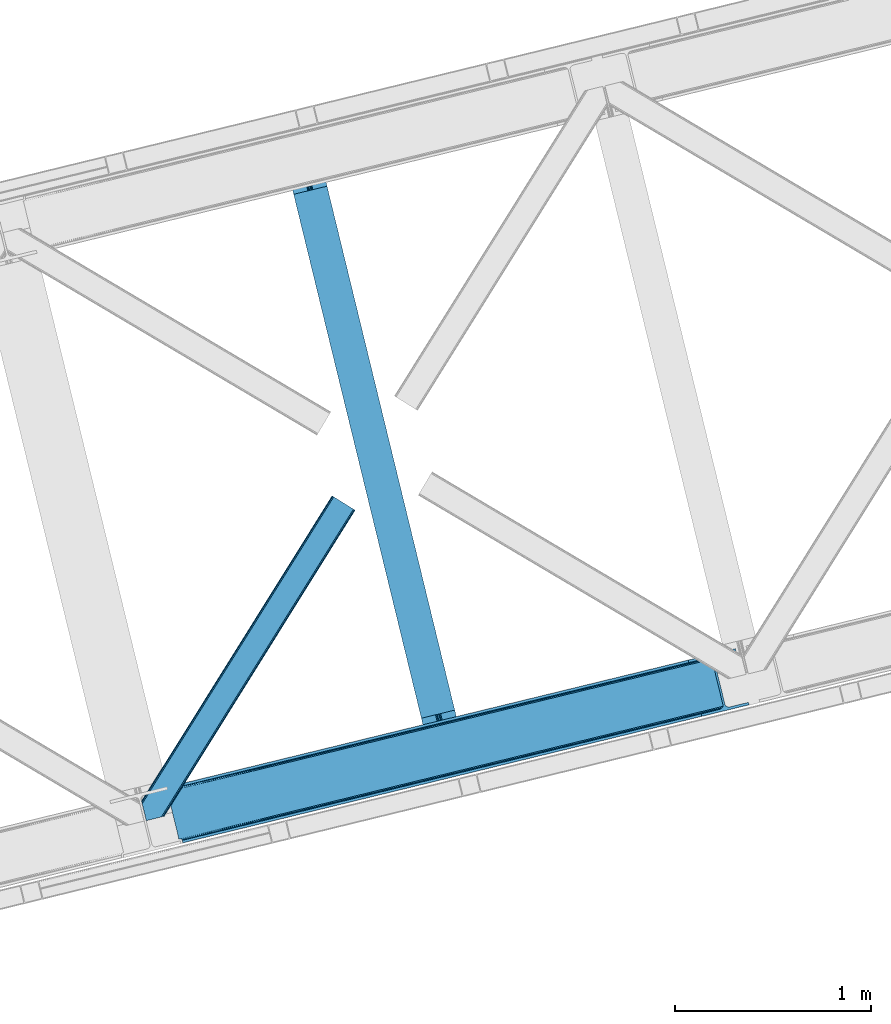
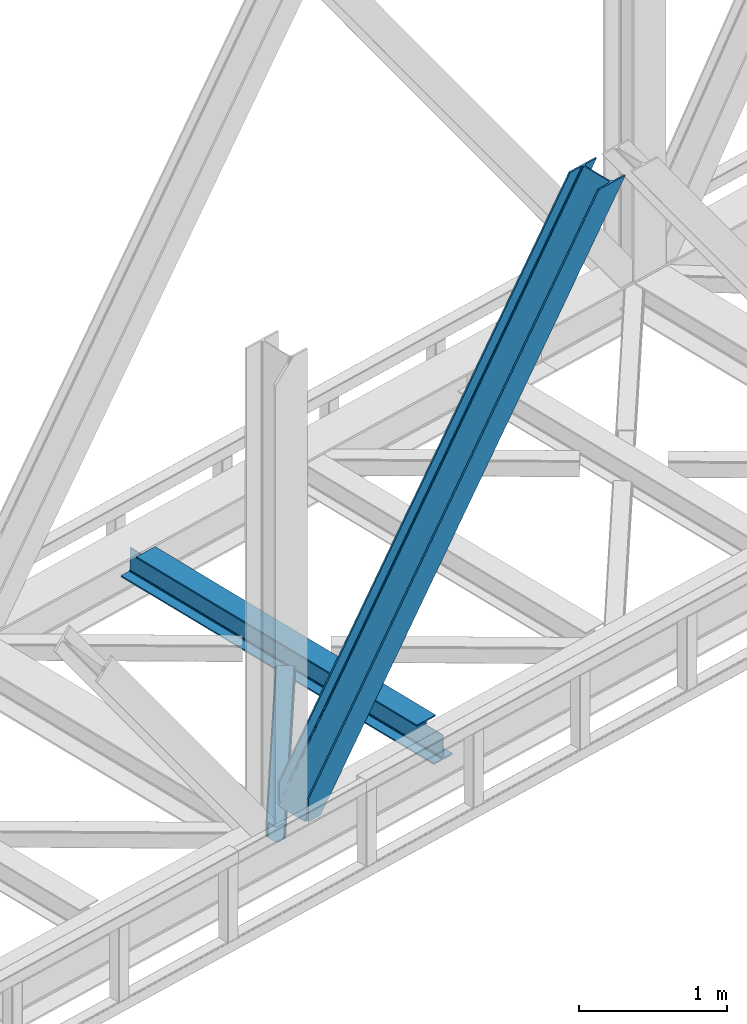
# One storey, part 67 of 93: 2 members, 1 beam.
"""IFC4 building model written with IfcOpenShell, lengths in millimetres."""

import ifcopenshell
import ifcopenshell.guid

model = None  # the IFC model being written
_history = None  # IfcOwnerHistory: only IFC2X3 demands one
_inside = {}  # id of a spatial element -> (the spatial element, [elements in it])
_under = {}  # id of a project, library or spatial element -> (it, [spatial elements below it])
_declared = {}  # id of a project -> (the project, [libraries it declares])
_typed = {}  # id of a type object -> (the type object, [elements of that type])
_made_of = {}  # id of a material, layer set ... -> (it, [elements and type objects made of it])


def new_model(schema):
    """Start an empty IFC model of exactly this schema.

    Asked for "IFC4X3", IfcOpenShell would pick the latest addendum, in which some entities
    have other attributes; the version numbers below select the first issue.
    IFC2X3 requires an IfcOwnerHistory on every rooted entity: one is made here for all.
    """
    global model, _history
    if schema == "IFC4X3":
        model = ifcopenshell.file(schema_version=(4, 3, 0, 0))
    else:
        model = ifcopenshell.file(schema=schema)
    _inside.clear()
    _under.clear()
    _declared.clear()
    _typed.clear()
    _made_of.clear()
    _history = None
    if model.schema == "IFC2X3":
        org = make("IfcOrganization", Name="unknown")
        user = make(
            "IfcPersonAndOrganization",
            ThePerson=make("IfcPerson", FamilyName="unknown"),
            TheOrganization=org,
        )
        app = make(
            "IfcApplication",
            ApplicationDeveloper=org,
            Version="unknown",
            ApplicationFullName="unknown",
            ApplicationIdentifier="unknown",
        )
        _history = make(
            "IfcOwnerHistory",
            OwningUser=user,
            OwningApplication=app,
            ChangeAction="ADDED",
            CreationDate=0,
        )
    return model


def make(cls, **values):
    """One entity of the class cls with the attributes given. An attribute that is None is left unset."""
    return model.create_entity(
        cls, **{name: value for name, value in values.items() if value is not None}
    )


def entity(cls, *values):
    """Any entity or typed value of the class cls, its attributes in the order of the schema. None: left unset."""
    e = model.create_entity(cls)
    for i, value in enumerate(values):
        if value is not None:
            e[i] = value
    return e


def rooted(cls, **values):
    """An entity with a GlobalId (a new one), such as an element, a storey or a relation."""
    return make(cls, GlobalId=ifcopenshell.guid.new(), OwnerHistory=_history, **values)


def si_unit(unit_type, name, prefix=None):
    """IfcSIUnit, for example si_unit("LENGTHUNIT", "METRE", prefix="MILLI")."""
    return make("IfcSIUnit", UnitType=unit_type, Prefix=prefix, Name=name)


def converted_unit(unit_type, name, factor, base, dimensions=None, offset=None):
    """IfcConversionBasedUnit, such as the inch: factor (a typed value) times the base unit."""
    return make(
        "IfcConversionBasedUnit"
        if offset is None
        else "IfcConversionBasedUnitWithOffset",
        ConversionOffset=offset,
        Dimensions=None
        if dimensions is None
        else entity("IfcDimensionalExponents", *dimensions),
        UnitType=unit_type,
        Name=name,
        ConversionFactor=make(
            "IfcMeasureWithUnit", ValueComponent=factor, UnitComponent=base
        ),
    )


def derived_unit(unit_type, elements):
    """IfcDerivedUnit: a product of units, each with its exponent."""
    return make(
        "IfcDerivedUnit",
        Elements=[
            make("IfcDerivedUnitElement", Unit=unit, Exponent=power)
            for unit, power in elements
        ],
        UnitType=unit_type,
    )


def assignment(units):
    """IfcUnitAssignment: the units of a project."""
    return None if units is None else make("IfcUnitAssignment", Units=units)


def point(xyz):
    """IfcCartesianPoint."""
    return None if xyz is None else make("IfcCartesianPoint", Coordinates=xyz)


def direction(xyz):
    """IfcDirection."""
    return None if xyz is None else make("IfcDirection", DirectionRatios=xyz)


def frame(location, z_axis=None, x_axis=None):
    """IfcAxis2Placement3D, a coordinate frame: its origin and axes. An axis left out is left unset."""
    return make(
        "IfcAxis2Placement3D",
        Location=point(location),
        Axis=direction(z_axis),
        RefDirection=direction(x_axis),
    )


def origin():
    """The frame at (0, 0, 0) with its axes left unset."""
    return frame((0.0, 0.0, 0.0))


def place(relative_to, where):
    """IfcLocalPlacement: puts the frame where relative to a parent placement (None: the world)."""
    return make(
        "IfcLocalPlacement", PlacementRelTo=relative_to, RelativePlacement=where
    )


def context(
    kind, dimensions, precision=None, world=None, true_north=None, identifier=None
):
    """IfcGeometricRepresentationContext, for example the 3D "Model" context."""
    return make(
        "IfcGeometricRepresentationContext",
        ContextIdentifier=identifier,
        ContextType=kind,
        CoordinateSpaceDimension=dimensions,
        Precision=precision,
        WorldCoordinateSystem=world,
        TrueNorth=true_north,
    )


def subcontext(parent, identifier, kind, view, scale=None):
    """IfcGeometricRepresentationSubContext, for example "Body" below "Model"."""
    return make(
        "IfcGeometricRepresentationSubContext",
        ContextIdentifier=identifier,
        ContextType=kind,
        ParentContext=parent,
        TargetScale=scale,
        TargetView=view,
    )


def project(units=None, contexts=None):
    """IfcProject with its units and contexts."""
    return rooted(
        "IfcProject",
        Name="project",
        RepresentationContexts=contexts,
        UnitsInContext=assignment(units),
    )


def spatial(cls, under=None, at=None, **own):
    """A site, building, storey or space (cls), placed at a placement, below another one or the project."""
    s = rooted(cls, ObjectPlacement=at, **own)
    if under is not None:
        _under.setdefault(under.id(), (under, []))[1].append(s)
    return s


def point_list(points):
    """IfcCartesianPointList2D or 3D."""
    cls = (
        "IfcCartesianPointList2D" if len(points[0]) == 2 else "IfcCartesianPointList3D"
    )
    return make(cls, CoordList=points)


def triangles(points, corners, closed=None, point_numbers=None):
    """IfcTriangulatedFaceSet: each triangle names its three corners, points numbered from 1."""
    return make(
        "IfcTriangulatedFaceSet",
        Coordinates=point_list(points),
        Closed=closed,
        CoordIndex=corners,
        PnIndex=point_numbers,
    )


def polygons(points, faces, closed=None, point_numbers=None):
    """IfcPolygonalFaceSet: a face is its outer loop, then its inner loops; points numbered from 1."""
    made = []
    for loops in faces:
        if len(loops) == 1:
            made.append(make("IfcIndexedPolygonalFace", CoordIndex=loops[0]))
        else:
            made.append(
                make(
                    "IfcIndexedPolygonalFaceWithVoids",
                    CoordIndex=loops[0],
                    InnerCoordIndices=loops[1:],
                )
            )
    return make(
        "IfcPolygonalFaceSet",
        Coordinates=point_list(points),
        Closed=closed,
        Faces=made,
        PnIndex=point_numbers,
    )


def shape(context_of_items, identifier, shape_type, items):
    """IfcShapeRepresentation: the items that make up one representation, for example the "Body"."""
    return make(
        "IfcShapeRepresentation",
        ContextOfItems=context_of_items,
        RepresentationIdentifier=identifier,
        RepresentationType=shape_type,
        Items=items,
    )


def material(Name=None, Category=None):
    """IfcMaterial."""
    return make("IfcMaterial", Name=Name, Category=Category)


def made_of(thing, what):
    """Note that an element or type object is made of a material, layer set ...; save() writes the relation."""
    if what is not None:
        _made_of.setdefault(what.id(), (what, []))[1].append(thing)
    return thing


def type_object(cls, material=None, **own):
    """A type object (cls), such as IfcWallType, which elements share."""
    return made_of(rooted(cls, **own), material)


def element(
    cls,
    number,
    at=None,
    inside=None,
    cuts=None,
    type_object=None,
    material=None,
    context=None,
    identifier="Body",
    shape_type=None,
    held_by="IfcProductDefinitionShape",
    body=None,
    shapes=None,
    **own,
):
    """One element of the class cls, such as IfcWall. Its Tag is "e" and its number.

    at: its placement. inside: the storey or other place that contains it. cuts: it is an
    opening in that element (IfcRelVoidsElement). A single representation is given by context,
    identifier, shape_type and body (its items); several are given by shapes. held_by: the class
    of the entity that holds the representations. save() writes the other relations.
    """
    e = rooted(cls, Tag="e%d" % number, ObjectPlacement=at, **own)
    if body is not None:
        shapes = [shape(context, identifier, shape_type, body)]
    if shapes is not None:
        e.Representation = make(held_by, Representations=shapes)
    if inside is not None:
        _inside.setdefault(inside.id(), (inside, []))[1].append(e)
    if cuts is not None:
        rooted(
            "IfcRelVoidsElement", RelatingBuildingElement=cuts, RelatedOpeningElement=e
        )
    if type_object is not None:
        _typed.setdefault(type_object.id(), (type_object, []))[1].append(e)
    return made_of(e, material)


def aggregate(whole, parts):
    """IfcRelAggregates: a whole, such as a stair, and the parts it consists of."""
    return rooted("IfcRelAggregates", RelatingObject=whole, RelatedObjects=parts)


def save(model, path):
    """Write the relations noted so far, then the file.

    IfcRelAggregates (storeys below a building ...), IfcRelContainedInSpatialStructure (elements
    in a storey), IfcRelDefinesByType, IfcRelAssociatesMaterial and IfcRelDeclares: one each for
    every whole, place, type object, material and project.
    """
    for whole, parts in _under.values():
        aggregate(whole, parts)
    for where, things in _inside.values():
        rooted(
            "IfcRelContainedInSpatialStructure",
            RelatedElements=things,
            RelatingStructure=where,
        )
    for kind, things in _typed.values():
        rooted("IfcRelDefinesByType", RelatedObjects=things, RelatingType=kind)
    for what, things in _made_of.values():
        rooted("IfcRelAssociatesMaterial", RelatedObjects=things, RelatingMaterial=what)
    for by, libraries in _declared.values():
        rooted("IfcRelDeclares", RelatingContext=by, RelatedDefinitions=libraries)
    model.write(path)


model = new_model("IFC4")

# Units and contexts
model_context = context("Model", 3, precision=0.01, world=origin(), true_north=direction((6.12303176911189e-17, 1.0)))
plan_context = context("Plan", 3, precision=0.01, world=origin(), true_north=direction((6.12303176911189e-17, 1.0)))
body_context = subcontext(model_context, "Body", "Model", "MODEL_VIEW")
ifc_project = project(units=[si_unit("LENGTHUNIT", "METRE", prefix="MILLI"), si_unit("AREAUNIT", "SQUARE_METRE"), si_unit("VOLUMEUNIT", "CUBIC_METRE"), converted_unit("PLANEANGLEUNIT", "DEGREE", entity("IfcRatioMeasure", 0.0174532925199433), si_unit("PLANEANGLEUNIT", "RADIAN"), dimensions=[0, 0, 0, 0, 0, 0, 0]), si_unit("MASSUNIT", "GRAM", prefix="KILO"), derived_unit("MASSDENSITYUNIT", [(si_unit("MASSUNIT", "GRAM", prefix="KILO"), 1), (si_unit("LENGTHUNIT", "METRE"), -3)]), derived_unit("MOMENTOFINERTIAUNIT", [(si_unit("LENGTHUNIT", "METRE"), 4)]), si_unit("TIMEUNIT", "SECOND"), si_unit("FREQUENCYUNIT", "HERTZ"), si_unit("THERMODYNAMICTEMPERATUREUNIT", "DEGREE_CELSIUS"), derived_unit("THERMALTRANSMITTANCEUNIT", [(si_unit("MASSUNIT", "GRAM", prefix="KILO"), 1), (si_unit("THERMODYNAMICTEMPERATUREUNIT", "KELVIN"), -1), (si_unit("TIMEUNIT", "SECOND"), -3)]), derived_unit("VOLUMETRICFLOWRATEUNIT", [(si_unit("LENGTHUNIT", "METRE"), 3), (si_unit("TIMEUNIT", "SECOND"), -1)]), derived_unit("MASSFLOWRATEUNIT", [(si_unit("MASSUNIT", "GRAM", prefix="KILO"), 1), (si_unit("TIMEUNIT", "SECOND"), -1)]), derived_unit("ROTATIONALFREQUENCYUNIT", [(si_unit("TIMEUNIT", "SECOND"), -1)]), si_unit("ELECTRICCURRENTUNIT", "AMPERE"), si_unit("ELECTRICVOLTAGEUNIT", "VOLT"), si_unit("POWERUNIT", "WATT"), si_unit("FORCEUNIT", "NEWTON", prefix="KILO"), si_unit("ILLUMINANCEUNIT", "LUX"), si_unit("LUMINOUSFLUXUNIT", "LUMEN"), si_unit("LUMINOUSINTENSITYUNIT", "CANDELA"), derived_unit("USERDEFINED", [(si_unit("MASSUNIT", "GRAM", prefix="KILO"), -1), (si_unit("LENGTHUNIT", "METRE"), -2), (si_unit("TIMEUNIT", "SECOND"), 3), (si_unit("LUMINOUSFLUXUNIT", "LUMEN"), 1)]), derived_unit("LINEARVELOCITYUNIT", [(si_unit("LENGTHUNIT", "METRE"), 1), (si_unit("TIMEUNIT", "SECOND"), -1)]), si_unit("PRESSUREUNIT", "PASCAL"), derived_unit("USERDEFINED", [(si_unit("LENGTHUNIT", "METRE"), -2), (si_unit("MASSUNIT", "GRAM", prefix="KILO"), 1), (si_unit("TIMEUNIT", "SECOND"), -2)]), derived_unit("LINEARFORCEUNIT", [(si_unit("MASSUNIT", "GRAM", prefix="KILO"), 1), (si_unit("LENGTHUNIT", "METRE"), 1), (si_unit("TIMEUNIT", "SECOND"), -2), (si_unit("LENGTHUNIT", "METRE"), -1)]), derived_unit("PLANARFORCEUNIT", [(si_unit("MASSUNIT", "GRAM", prefix="KILO"), 1), (si_unit("LENGTHUNIT", "METRE"), 1), (si_unit("TIMEUNIT", "SECOND"), -2), (si_unit("LENGTHUNIT", "METRE"), -2)])], contexts=[model_context, plan_context])

# Site, building, storey
site_placement = place(None, origin())
site = spatial("IfcSite", under=ifc_project, at=site_placement, CompositionType="ELEMENT")
building_placement = place(site_placement, origin())
building = spatial("IfcBuilding", under=site, at=building_placement, CompositionType="ELEMENT")
storey_placement = place(building_placement, frame((0.0, 0.0, 15900.0)))
storey = spatial("IfcBuildingStorey", under=building, at=storey_placement, CompositionType="ELEMENT", Elevation=15900.0)

# Beam
ifc_material = material(Name="Metal painted (White)")
beam_type = type_object("IfcBeamType", PredefinedType="BEAM")
beam_placement = place(storey_placement, frame((-16428.8373794075, 13790.2262877449, 3441.0)))
element("IfcBeam", 1, at=beam_placement, inside=storey, type_object=beam_type, material=ifc_material, ObjectType="Steel Beam", PredefinedType="BEAM", context=body_context, shape_type="Tessellation", body=[
    polygons([(896.722476515603, 41.444566273306, 11.000000000004), (896.722476515603, 41.444566273306, 2.16573425859679e-12), (170.021610174752, 3022.65205668042, 2.16573425859679e-12), (170.021610174752, 3022.65205668042, 11.000000000004), (830.656936561984, 25.3403919499634, 11.000000000004), (103.956070221131, 3006.54788235708, 11.000000000004), (824.708186540694, 23.8903211957374, 12.2179274798217), (98.0073201998448, 3005.09781160285, 12.2179274798217), (819.665079784581, 22.6610105689172, 15.6862915010192), (92.9642134437297, 3003.86850097603, 15.6862915010192), (816.295383581413, 21.8396114687097, 20.8770650821678), (89.5945172405625, 3003.04710187582, 20.8770650821678), (815.112103631723, 21.5511744621184, 27.0000000000047), (88.4112372908744, 3002.75866486923, 27.0000000000047), (81.6103728838758, 3001.1008822183, 27.0000000000025), (81.6103728838758, 3001.1008822183, 203.000000000006), (88.4112372908723, 3002.75866486924, 203.000000000006), (0.0, 2981.20749040711, 2.16573425859679e-12), (2.16573425859679e-12, 2981.20749040711, 10.9999999999997), (66.0655399536107, 2997.31166473045, 11.000000000004), (72.0142899749097, 2998.76173548468, 12.2179274798217), (77.0573967310097, 2999.9910461115, 15.686291501017), (80.4270929341942, 3000.81244521171, 20.8770650821657), (815.112103631723, 21.5511744621227, 203.000000000006), (808.311239224729, 19.8933918111854, 203.000000000006), (808.311239224729, 19.8933918111854, 27.0000000000025), (807.127959275045, 19.6049548045963, 20.8770650821657), (803.758263071858, 18.7835557043844, 15.686291501017), (798.715156315761, 17.5542450775664, 12.2179274798217), (792.766406294464, 16.1041743233425, 11.000000000004), (726.700866340851, 2.16573425859679e-12, 10.9999999999997), (726.700866340851, 2.16573425859679e-12, 2.16573425859679e-12), (775.945201911955, 182.229070489532, 203.069792164282), (124.290390378911, 2855.5685280608, 203.000000000006), (124.513271168059, 2854.65418562638, 203.617301946336), (124.526185412585, 2854.60120565348, 217.000003693143), (775.799998669231, 182.824605273256, 217.000003676718), (775.800869277125, 182.821033832377, 204.00000679514), (769.234900758903, 180.199471824632, 203.006342981088), (769.012053092181, 181.113823838958, 203.617301946336), (768.999138847653, 181.166803811849, 217.000003693143), (117.725325591006, 2852.94340419208, 217.000003676718), (117.724454983112, 2852.94697563296, 204.00000679514), (117.58015539406, 2853.53894853353, 203.076120467494), (117.489525971919, 2853.91074540987, 203.000000000006), (776.98348339326, 183.112202246696, 223.122939328039), (780.352479801942, 183.936472070578, 228.313710402595), (785.395115205964, 185.167716295882, 231.782072735464), (791.343694076665, 186.618489150561, 232.999999602236), (857.409144942182, 202.723028934495, 232.999999283132), (857.407671605746, 202.729072911368, 243.999994005812), (687.38629070184, 161.28356611448, 243.999994827032), (687.38776403828, 161.277522137607, 233.000000104353), (753.453214903791, 177.382061921541, 232.999999785253), (759.402120032125, 178.831496389766, 231.782072861012), (764.445684539247, 180.058929212897, 228.313710479431), (767.816071448994, 180.87749487033, 223.12293937232), (116.541840866966, 2852.65580721863, 223.122939328039), (113.172844458285, 2851.83153739475, 228.313710402599), (108.13020905427, 2850.60029316945, 231.782072735464), (102.181630183564, 2849.14952031477, 232.999999602236), (36.1161793180448, 2833.04498053083, 232.999999283128), (36.1176526544823, 2833.03893655396, 243.999994005812), (206.13903355839, 2874.48444335085, 243.999994827032), (206.137560221948, 2874.49048732772, 233.000000104357), (140.072109356434, 2858.38594754379, 232.999999785253), (134.123204228108, 2856.93651307556, 231.782072861012), (129.079639720982, 2855.70908025243, 228.313710479427), (125.709252811237, 2854.890514595, 223.12293937232)], [[[1, 2, 3, 4]], [[5, 1, 4, 6]], [[7, 5, 6, 8]], [[9, 7, 8, 10]], [[11, 9, 10, 12]], [[13, 11, 12, 14]], [[15, 16, 17, 14, 12, 10, 8, 6, 4, 3, 18, 19, 20, 21, 22, 23]], [[13, 24, 25, 26, 27, 28, 29, 30, 31, 32, 2, 1, 5, 7, 9, 11]], [[2, 32, 18, 3]], [[32, 31, 19, 18]], [[31, 30, 20, 19]], [[27, 26, 15, 23]], [[28, 27, 23, 22]], [[29, 28, 22, 21]], [[30, 29, 21, 20]], [[33, 24, 13, 14, 17, 34, 35, 36, 37, 38]], [[25, 39, 40, 41, 42, 43, 44, 16, 15, 26]], [[39, 25, 24, 33]], [[45, 34, 17, 16]], [[41, 40, 38, 37, 46, 47, 48, 49, 50, 51, 52, 53, 54, 55, 56, 57]], [[42, 58, 59, 60, 61, 62, 63, 64, 65, 66, 67, 68, 69, 36, 35, 43]], [[46, 37, 36, 69]], [[47, 46, 69, 68]], [[48, 47, 68, 67]], [[49, 48, 67, 66]], [[50, 49, 66, 65]], [[51, 50, 65, 64]], [[52, 51, 64, 63]], [[53, 52, 63, 62]], [[54, 53, 62, 61]], [[55, 54, 61, 60]], [[56, 55, 60, 59]], [[57, 56, 59, 58]], [[41, 57, 58, 42]]], closed=False),
])

# Members
member_type_1 = type_object("IfcMemberType", PredefinedType="BRACE")
member_1_placement = place(storey_placement, frame((-17038.2890716553, 13316.0499938965, 3694.99929199219)))
element("IfcMember", 2, at=member_1_placement, inside=storey, type_object=member_type_1, ObjectType="Steel Vertical Brace", PredefinedType="BRACE", context=body_context, shape_type="Tessellation", body=[
    triangles([(58.5487518310547, 26.6239562988285, 0.0), (60.4428222656279, 18.8523376464855, 0.0), (59.1045318603537, 19.6697296142593, 0.80925292968459), (58.9696563720718, 18.4930572509766, 1.10690917968532), (64.089111328125, 19.7406555175785, 8.31577148437282), (64.089111328125, 19.7406555175785, 0.0), (522.90412902832, 126.715521240236, 658.855133056641), (68.3772216796897, 19.9243652343757, 14.8293273925774), (72.407208251956, 18.4523620605469, 22.4381652832017), (524.58542175293, 133.136059570314, 656.552947998047), (73.9838562011719, 17.2861541748061, 26.4425720214822), (2834.75371398926, 696.263314819336, 3911.00081176758), (2834.77231750489, 703.35823059082, 3911.00081176758), (2385.95087585449, 593.953280639649, 3278.7231262207), (2386.50665588379, 586.999053955078, 3279.53005371094), (2831.44228820801, 689.4462890625, 3911.00081176758), (2384.82652587891, 580.578515625, 3281.83223876953), (2825.34033508301, 683.941973876954, 3911.00081176758), (2381.17326049805, 575.671838378907, 3285.27854003906), (2817.37686767578, 680.591015625001, 3911.00081176758), (2376.0933380127, 573.023162841797, 3289.34108276367), (514.170941162112, 119.160168457032, 666.36397705078), (519.250863647463, 121.808843994142, 662.301434326171), (77.0987823486357, 12.6189971923832, 50.6410949707024), (76.5662567138679, 13.8991516113292, 38.6743835449197), (75.4046997070327, 15.4258026123061, 33.1630920410134), (524.028479003908, 140.090286254883, 655.74602050781), (990.065148925783, 246.601226806641, 1312.29896850586), (989.509368896486, 253.555453491212, 1311.48971557617), (1455.54603881836, 360.067556762697, 1968.04266357422), (1454.99025878906, 367.021783447266, 1967.23341064453), (1921.02692871094, 473.532723999024, 2623.78635864258), (1920.47114868164, 480.48811340332, 2622.97710571289), (988.385018920901, 240.180688476563, 1314.598828125), (1453.86590881348, 353.647018432617, 1970.34484863281), (1919.34563598633, 467.113348388673, 2626.08854370117), (984.73175354004, 235.274011230469, 1318.04512939453), (1450.21264343262, 348.740341186523, 1973.78882446289), (1915.69237060547, 462.20667114258, 2629.53251953125), (979.651831054689, 232.626498413087, 1322.10767211914), (1445.13272094727, 346.091665649416, 1977.85369262695), (1910.61361083985, 459.55799560547, 2633.59738769531), (77.0987823486357, 12.6189971923832, 182.433050537107), (2723.82443847656, 657.78659362793, 3911.00081176758), (75.5709686279297, 15.550213623048, 0.0), (77.381323242189, 11.6585906982436, 0.0), (77.381323242189, 11.6585906982436, 182.495837402341), (68.3772216796897, 19.9243652343757, 0.0), (72.407208251956, 18.4523620605469, 0.0), (2726.9033203125, 645.155969238282, 3911.00081176758), (80.223010253907, 0.0, 182.495837402341), (80.223010253907, 0.0, 0.0), (191.325531005859, 27.0820678710952, 0.0), (2967.5537475586, 703.817504882813, 3911.00081176758), (1399.80990600586, 593.394012451172, 1967.23341064453), (2779.59196472168, 929.729296875001, 3911.00081176758), (2330.77052307129, 820.325509643555, 3278.7231262207), (1865.29079589844, 706.859179687501, 2622.97710571289), (934.329016113283, 479.927682495118, 1311.48971557617), (468.848126220706, 366.461352539063, 655.74602050781), (3.36839904785302, 252.996185302734, 0.0), (2964.47486572266, 716.448129272461, 3911.00081176758), (188.246649169923, 39.7126922607422, 0.0), (2870.92243652344, 693.643707275391, 3911.00081176758), (94.6942199707046, 16.9082702636733, 0.0), (2862.31133422852, 692.954214477541, 3911.00081176758), (86.083117675782, 16.2199401855469, 0.0), (2854.36065673828, 695.031994628907, 3911.00081176758), (78.1324401855491, 18.2977203369155, 0.0), (2848.28312072754, 699.561950683594, 3911.00081176758), (72.0549041748054, 22.8265136718765, 0.0), (2845.00192565918, 705.852264404297, 3911.00081176758), (68.7737091064482, 29.1168273925796, 0.0), (2789.82157287598, 932.223330688477, 3911.00081176758), (13.5933563232429, 255.489056396485, 0.0), (2789.83901367188, 939.318246459961, 3911.00081176758), (13.6107971191414, 262.582809448242, 0.0), (2793.15160217285, 946.135272216798, 3911.00081176758), (16.9233856201172, 269.400997924806, 0.0), (2799.25355529785, 951.639587402344, 3911.00081176758), (23.0253387451194, 274.904150390626, 0.0), (2807.21585998535, 954.990545654298, 3911.00081176758), (30.9876434326179, 278.256271362305, 0.0), (2900.76828918457, 977.794967651367, 3911.00081176758), (124.540072631837, 301.060693359375, 0.0), (2897.68940734863, 990.425592041016, 3911.00081176758), (121.462353515628, 313.690155029297, 0.0), (2770.23323364258, 940.549566650392, 3911.00081176758), (2762.28255615235, 942.627346801759, 3911.00081176758), (2657.04014282227, 931.764056396485, 3911.00081176758), (2753.67145385742, 941.939016723634, 3911.00081176758), (2660.1190246582, 919.134594726564, 3911.00081176758), (2776.31076965332, 936.020773315431, 3911.00081176758), (10.3586700439482, 286.608087158203, 182.495837402341), (10.3586700439482, 286.608087158203, 0.0), (13.2015197753935, 274.949496459962, 182.495837402341), (13.3922058105491, 273.966998291016, 182.433050537107), (1381.42614440918, 607.439666748047, 1977.85369262695), (1846.90703430176, 720.904833984376, 2633.59738769531), (2312.38792419434, 834.37116394043, 3289.34108276367), (915.945254516602, 493.973336791993, 1322.10767211914), (13.3922058105491, 273.966998291016, 50.6410949707024), (450.465527343753, 380.508169555666, 666.36397705078), (13.2015197753935, 274.949496459962, 0.0), (13.5096405029326, 272.584524536134, 38.6743835449197), (13.385229492189, 270.661386108399, 0.0), (13.385229492189, 270.661386108399, 32.1678039550752), (12.4759826660156, 268.182467651368, 26.1867736816384), (11.9120635986328, 266.62907409668, 22.4381652832017), (11.9120635986328, 266.62907409668, 0.0), (9.01107788085938, 263.467639160157, 14.8293273925774), (9.01107788085938, 263.467639160157, 0.0), (5.11945495605687, 261.6572845459, 8.31577148437282), (5.11945495605687, 261.6572845459, 0.0), (1.47316589355614, 260.768966674805, 0.0), (461.695074462892, 377.818798828126, 658.855133056641), (456.194247436524, 380.494216918945, 662.301434326171), (466.141314697266, 372.892355346681, 656.552947998047), (0.661587524416973, 259.426025390625, 0.80925292968459), (0.0, 260.409686279298, 1.10690917968532), (2318.11664428711, 834.357211303712, 3285.27854003906), (2323.61747131348, 831.681793212891, 3281.83223876953), (2328.06371154785, 826.755349731446, 3279.53005371094), (921.673974609377, 493.959384155274, 1318.04512939453), (1387.15486450195, 607.425714111328, 1973.78882446289), (1852.63575439453, 720.890881347657, 2629.53251953125), (927.175964355471, 491.28512878418, 1314.598828125), (1392.65685424805, 604.750296020509, 1970.34484863281), (1858.1365814209, 718.216625976564, 2626.08854370117), (931.622204589845, 486.357522583008, 1312.29896850586), (1397.10309448242, 599.823852539063, 1968.04266357422), (1862.583984375, 713.289019775391, 2623.78635864258)], [[1, 2, 3], [4, 3, 2], [5, 4, 6], [2, 6, 4], [7, 8, 9], [10, 3, 8], [8, 7, 10], [9, 11, 7], [3, 4, 5], [5, 8, 3], [12, 13, 14], [14, 15, 12], [16, 12, 15], [15, 17, 16], [18, 16, 17], [17, 19, 18], [20, 18, 19], [19, 21, 20], [22, 23, 24], [25, 24, 23], [25, 7, 26], [25, 23, 7], [11, 26, 7], [10, 27, 1], [1, 3, 10], [28, 29, 10], [27, 10, 29], [30, 31, 28], [29, 28, 31], [32, 33, 31], [31, 30, 32], [15, 14, 33], [33, 32, 15], [34, 28, 10], [10, 7, 34], [35, 30, 28], [28, 34, 35], [36, 32, 35], [30, 35, 32], [17, 15, 32], [32, 36, 17], [37, 34, 7], [7, 23, 37], [38, 35, 34], [34, 37, 38], [39, 36, 35], [35, 38, 39], [19, 17, 39], [36, 39, 17], [40, 37, 22], [23, 22, 37], [41, 38, 40], [37, 40, 38], [42, 39, 41], [38, 41, 39], [21, 19, 39], [39, 42, 21], [41, 43, 44], [44, 21, 42], [21, 44, 20], [42, 41, 44], [43, 41, 40], [40, 22, 43], [24, 43, 22], [45, 11, 9], [45, 26, 11], [46, 25, 26], [46, 47, 24], [43, 24, 47], [24, 25, 46], [26, 45, 46], [48, 8, 5], [5, 6, 48], [49, 9, 8], [8, 48, 49], [9, 49, 45], [47, 44, 43], [50, 47, 51], [47, 50, 44], [52, 51, 46], [47, 46, 51], [50, 53, 54], [53, 50, 51], [52, 53, 51], [33, 55, 31], [13, 56, 57], [58, 14, 57], [55, 33, 58], [57, 14, 13], [58, 33, 14], [31, 59, 29], [59, 60, 27], [59, 31, 55], [61, 1, 60], [59, 27, 29], [60, 1, 27], [62, 54, 53], [53, 63, 62], [64, 62, 63], [63, 65, 64], [66, 64, 65], [65, 67, 66], [68, 66, 67], [67, 69, 68], [70, 68, 69], [69, 71, 70], [72, 70, 71], [71, 73, 72], [74, 72, 75], [73, 75, 72], [76, 74, 77], [75, 77, 74], [78, 76, 79], [77, 79, 76], [80, 78, 81], [79, 81, 78], [82, 80, 83], [81, 83, 80], [84, 82, 85], [83, 85, 82], [86, 84, 85], [85, 87, 86], [56, 13, 74], [16, 18, 66], [20, 50, 54], [44, 50, 20], [18, 20, 64], [13, 12, 70], [12, 16, 68], [88, 80, 89], [90, 91, 86], [91, 89, 82], [90, 92, 91], [88, 93, 78], [93, 56, 76], [74, 13, 72], [64, 66, 18], [70, 12, 68], [66, 68, 16], [70, 72, 13], [54, 64, 20], [54, 62, 64], [82, 89, 80], [78, 93, 76], [74, 76, 56], [78, 80, 88], [82, 86, 91], [86, 82, 84], [90, 87, 94], [90, 86, 87], [87, 95, 94], [96, 90, 94], [92, 96, 97], [96, 92, 90], [92, 97, 98], [98, 99, 92], [99, 100, 92], [91, 92, 100], [101, 98, 97], [97, 102, 103], [103, 101, 97], [104, 96, 94], [94, 95, 104], [104, 105, 102], [104, 106, 107], [107, 105, 104], [96, 104, 102], [102, 97, 96], [108, 106, 109], [108, 107, 106], [110, 109, 106], [109, 110, 111], [112, 111, 110], [111, 112, 113], [114, 113, 112], [75, 73, 61], [114, 75, 61], [114, 112, 75], [114, 61, 115], [79, 77, 110], [77, 75, 112], [106, 79, 110], [110, 77, 112], [73, 1, 61], [6, 73, 48], [1, 6, 2], [1, 73, 6], [48, 71, 49], [49, 71, 69], [73, 71, 48], [45, 49, 69], [104, 81, 79], [79, 106, 104], [95, 81, 104], [83, 95, 87], [87, 85, 83], [83, 81, 95], [45, 69, 46], [52, 67, 65], [46, 69, 67], [52, 46, 67], [65, 53, 52], [53, 65, 63], [116, 117, 105], [105, 107, 116], [118, 111, 113], [113, 119, 118], [118, 116, 108], [108, 109, 118], [109, 111, 118], [113, 120, 119], [107, 108, 116], [117, 103, 102], [102, 105, 117], [89, 91, 121], [100, 121, 91], [88, 89, 122], [121, 122, 89], [93, 88, 123], [122, 123, 88], [56, 93, 57], [123, 57, 93], [124, 101, 103], [103, 117, 124], [125, 98, 101], [101, 124, 125], [126, 99, 98], [98, 125, 126], [121, 100, 126], [99, 126, 100], [127, 124, 116], [117, 116, 124], [128, 125, 127], [124, 127, 125], [129, 126, 128], [125, 128, 126], [122, 121, 126], [126, 129, 122], [130, 127, 118], [116, 118, 127], [131, 128, 130], [127, 130, 128], [132, 129, 128], [128, 131, 132], [123, 122, 132], [129, 132, 122], [60, 118, 61], [119, 61, 118], [59, 130, 118], [118, 60, 59], [55, 131, 130], [130, 59, 55], [58, 132, 55], [131, 55, 132], [57, 123, 58], [132, 58, 123], [120, 113, 114], [114, 115, 120], [115, 61, 119], [119, 120, 115]]),
])
member_type_2 = type_object("IfcMemberType", PredefinedType="BRACE")
member_2_placement = place(storey_placement, frame((-17168.7764556885, 13429.4407470703, 3510.00011901855)))
element("IfcMember", 3, at=member_2_placement, inside=storey, type_object=member_type_2, ObjectType="Steel Horizontal Brace", PredefinedType="BRACE", context=body_context, shape_type="Tessellation", body=[
    triangles([(986.15143432617, 1647.42967529297, 0.0), (1075.22041625976, 1591.82725524902, 0.0), (119.789199829102, 259.603921508788, 0.0), (154.548706054688, 117.003323364257, 0.0), (115.903390502928, 275.544808959959, 4.52065429687718), (117.571893310545, 268.698715209961, 1.33247680664135), (158.434515380857, 101.062435913085, 4.52065429687718), (156.76601257324, 107.908529663086, 1.33247680664135), (114.825549316403, 275.743634033202, 5.52059326172093), (115.126693725586, 275.922692871092, 5.35316162109666), (158.127557373045, 99.1206939697258, 5.27525939941552), (115.440628051758, 276.107565307617, 5.18107910156323), (158.231039428709, 99.7776306152336, 5.02062377929906), (158.183367919919, 99.4811370849602, 5.13573303222802), (115.540621948239, 276.16686401367, 5.12526855468968), (115.682473754881, 275.92036743164, 4.88574829101708), (158.334521484372, 100.433404541014, 4.76482543945531), (158.032214355466, 98.4928253173821, 5.52059326172093), (1085.71744995117, 1585.27416687012, 5.12526855468968), (1080.90030212402, 1588.27979736328, 1.33247680664135), (1088.93469543457, 1583.26498718262, 10.8028289794929), (114.209307861325, 21.8533172607422, 10.8028289794929), (109.46541137695, 20.6964111328125, 5.52059326172093), (1090.06485900879, 1582.55921630859, 17.5000946044929), (116.061520385741, 22.304452514647, 17.5000946044929), (6.75075073241896, 102.619317626952, 5.52059326172093), (31.3608764648416, 1.65803833007703, 5.52059326172093), (1090.06485900879, 1582.55921630859, 122.500662231447), (116.061520385741, 22.304452514647, 122.500662231447), (1088.93469543457, 1583.26498718262, 129.197927856447), (114.209307861325, 21.8533172607422, 129.197927856447), (1085.71744995117, 1585.27416687012, 134.874325561526), (108.931723022459, 20.566186523436, 134.874325561526), (1080.90030212402, 1588.27979736328, 138.667117309571), (101.038018798827, 18.6418853759751, 138.667117309571), (1075.22041625976, 1591.82725524902, 139.999594116212), (91.7292846679666, 16.3734191894528, 139.999594116212), (980.470385742186, 1650.97597045898, 1.33247680664135), (975.654400634765, 1653.98160095215, 5.12526855468968), (1.68826904296657, 100.410150146483, 10.9621215820334), (972.43599243164, 1655.99078063965, 10.8028289794929), (971.306991577147, 1656.69655151367, 17.5000946044929), (0.239520263668965, 99.7776306152336, 12.5201660156272), (0.0, 100.760128784179, 17.5000946044929), (5.79266967773219, 76.9941375732415, 139.999594116212), (986.15143432617, 1647.42967529297, 139.999594116212), (24.5612915039055, 0.0, 139.999594116212), (971.306991577147, 1656.69655151367, 122.500662231447), (0.0, 100.760128784179, 122.500662231447), (980.470385742186, 1650.97597045898, 138.667117309571), (3.57536315917969, 86.088931274413, 138.667117309571), (975.654400634765, 1653.98160095215, 134.874325561526), (1.69640808105396, 93.7989257812496, 134.874325561526), (972.43599243164, 1655.99078063965, 129.197927856447), (0.44067077636646, 98.950936889647, 129.197927856447), (29.9249176025369, 1.30689697265552, 6.99957275390625), (12.1969299316406, 74.0326904296871, 6.99957275390625), (8.99131164550636, 81.5473480224609, 8.3320495605476), (3.88697204589698, 84.812265014647, 12.5201660156272), (1069.28124389648, 1595.53284301758, 6.99957275390625), (81.9961578369112, 14.000308227538, 6.99957275390625), (992.090606689451, 1643.72292480469, 6.99957275390625), (981.588922119139, 1650.27485046387, 12.1260040283232), (978.370513916014, 1652.28286743164, 17.8035644531265), (2.75797119140407, 89.4445404052731, 17.8035644531265), (986.406069946288, 1647.26805725098, 8.3320495605476), (977.241513061523, 1652.98863830566, 24.4996673583992), (2.31730041503761, 91.2537322998032, 24.4996673583992), (977.241513061523, 1652.98863830566, 115.501089477541), (2.31730041503761, 91.2537322998032, 115.501089477541), (4.01370849609157, 84.2925292968739, 127.87475280762), (2.75797119140407, 89.4445404052731, 122.196029663086), (5.89266357421729, 76.5825347900391, 131.667544555665), (8.10997009277344, 67.4865783691403, 133.000021362306), (24.5612915039055, 0.0, 133.000021362306), (978.370513916014, 1652.28286743164, 122.196029663086), (981.588922119139, 1650.27485046387, 127.87475280762), (986.406069946288, 1647.26805725098, 131.667544555665), (992.090606689451, 1643.72292480469, 133.000021362306), (1069.28124389648, 1595.53284301758, 133.000021362306), (81.9961578369112, 14.000308227538, 133.000021362306), (1079.77711486816, 1588.97975463867, 12.1260040283232), (1082.99552307129, 1586.9717376709, 17.8035644531265), (1084.12568664551, 1586.26596679687, 24.4996673583992), (1074.96112976074, 1591.98654785156, 8.3320495605476), (1079.77711486816, 1588.97975463867, 127.87475280762), (1084.12568664551, 1586.26596679687, 115.501089477541), (1082.99552307129, 1586.9717376709, 122.196029663086), (1074.96112976074, 1591.98654785156, 131.667544555665), (91.3048919677713, 16.2699371337876, 131.667544555665), (99.1985961914033, 18.1942382812485, 127.87475280762), (104.476181030273, 19.4802062988274, 122.196029663086), (106.329556274413, 19.931341552734, 115.501089477541), (91.3048919677713, 16.2699371337876, 8.3320495605476), (104.476181030273, 19.4802062988274, 17.8035644531265), (99.1985961914033, 18.1942382812485, 12.1260040283232), (106.329556274413, 19.931341552734, 24.4996673583992)], [[1, 2, 3], [4, 3, 2], [5, 3, 4], [3, 5, 6], [4, 7, 5], [7, 4, 8], [9, 10, 11], [10, 12, 13], [13, 14, 10], [12, 15, 16], [16, 17, 12], [16, 5, 7], [7, 17, 16], [17, 13, 12], [14, 11, 10], [11, 18, 9], [19, 14, 13], [13, 20, 19], [13, 17, 20], [17, 7, 20], [7, 8, 20], [21, 22, 18], [18, 19, 21], [14, 19, 11], [18, 11, 19], [22, 23, 18], [21, 24, 25], [25, 22, 21], [2, 20, 4], [8, 4, 20], [23, 26, 18], [23, 27, 26], [9, 18, 26], [24, 28, 29], [29, 25, 24], [28, 30, 29], [31, 29, 30], [30, 32, 31], [33, 31, 32], [32, 34, 33], [35, 33, 34], [34, 36, 35], [37, 35, 36], [38, 6, 5], [5, 39, 38], [5, 15, 39], [40, 41, 9], [41, 39, 15], [42, 41, 40], [40, 43, 42], [43, 44, 42], [9, 26, 40], [38, 1, 6], [3, 6, 1], [36, 45, 37], [36, 46, 45], [45, 47, 37], [48, 42, 49], [44, 49, 42], [46, 50, 51], [51, 45, 46], [50, 52, 53], [53, 51, 50], [52, 54, 55], [55, 53, 52], [54, 48, 49], [49, 55, 54], [27, 56, 57], [26, 57, 58], [57, 26, 27], [59, 40, 26], [26, 58, 59], [43, 40, 59], [60, 57, 61], [60, 62, 57], [57, 56, 61], [63, 64, 65], [65, 59, 63], [66, 63, 59], [62, 66, 58], [58, 57, 62], [59, 58, 66], [64, 67, 68], [68, 65, 64], [67, 69, 70], [70, 68, 67], [71, 53, 72], [73, 74, 45], [74, 47, 45], [74, 75, 47], [51, 73, 45], [71, 51, 53], [71, 73, 51], [49, 68, 70], [55, 72, 53], [70, 72, 49], [72, 55, 49], [44, 68, 49], [43, 59, 65], [65, 68, 44], [44, 43, 65], [69, 76, 70], [72, 70, 76], [76, 77, 72], [71, 72, 77], [77, 78, 71], [73, 71, 78], [78, 79, 73], [74, 73, 79], [80, 74, 79], [74, 80, 81], [75, 74, 81], [21, 82, 83], [84, 28, 24], [21, 83, 24], [21, 19, 82], [83, 84, 24], [82, 19, 20], [60, 2, 1], [2, 85, 20], [85, 2, 60], [85, 82, 20], [30, 86, 32], [87, 28, 84], [28, 88, 30], [88, 28, 87], [30, 88, 86], [36, 80, 46], [34, 32, 86], [86, 89, 34], [89, 80, 36], [36, 34, 89], [63, 38, 39], [1, 62, 60], [1, 66, 62], [66, 1, 38], [63, 66, 38], [67, 42, 48], [41, 64, 63], [39, 41, 63], [64, 41, 42], [67, 64, 42], [50, 77, 52], [46, 80, 79], [79, 78, 46], [78, 77, 50], [50, 46, 78], [54, 52, 77], [48, 69, 67], [76, 48, 54], [48, 76, 69], [76, 54, 77], [35, 37, 90], [47, 81, 37], [81, 47, 75], [81, 90, 37], [91, 35, 90], [91, 33, 35], [33, 92, 31], [92, 33, 91], [29, 92, 93], [92, 29, 31], [61, 23, 94], [95, 96, 23], [96, 94, 23], [61, 27, 23], [27, 61, 56], [97, 95, 25], [22, 25, 95], [29, 97, 25], [97, 29, 93], [95, 23, 22], [80, 89, 90], [90, 81, 80], [89, 86, 91], [91, 90, 89], [86, 88, 92], [92, 91, 86], [88, 87, 93], [93, 92, 88], [87, 84, 93], [97, 93, 84], [84, 83, 97], [95, 97, 83], [83, 82, 95], [96, 95, 82], [82, 85, 96], [94, 96, 85], [85, 60, 94], [61, 94, 60]]),
])

save(model, "model.ifc")
